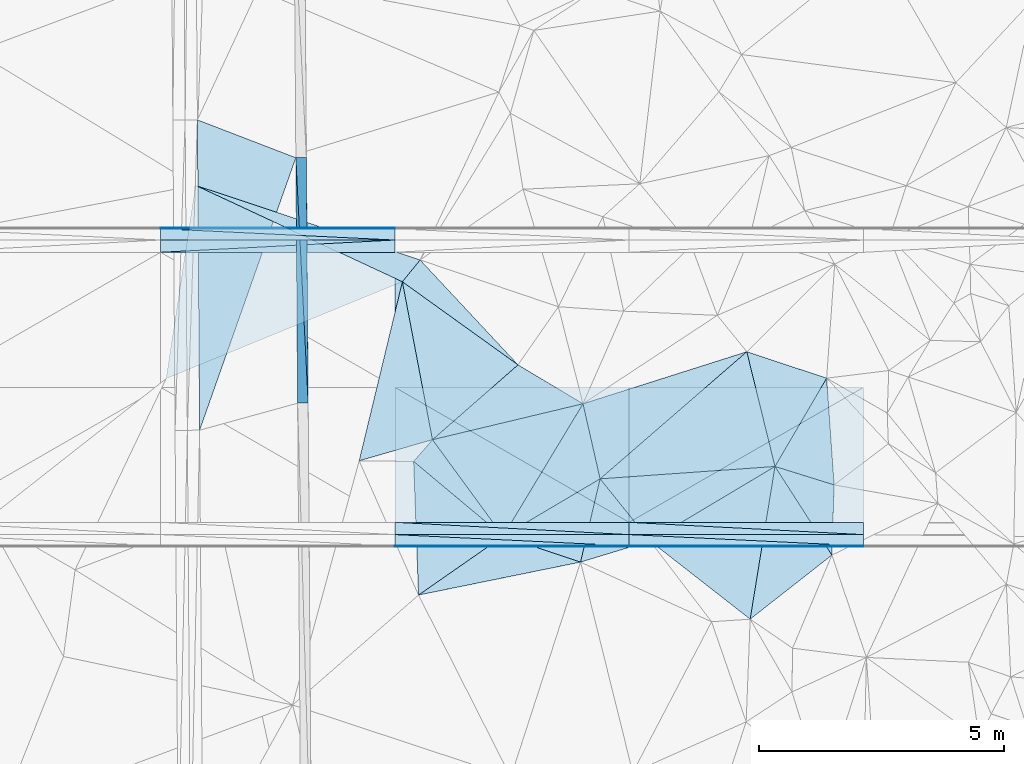
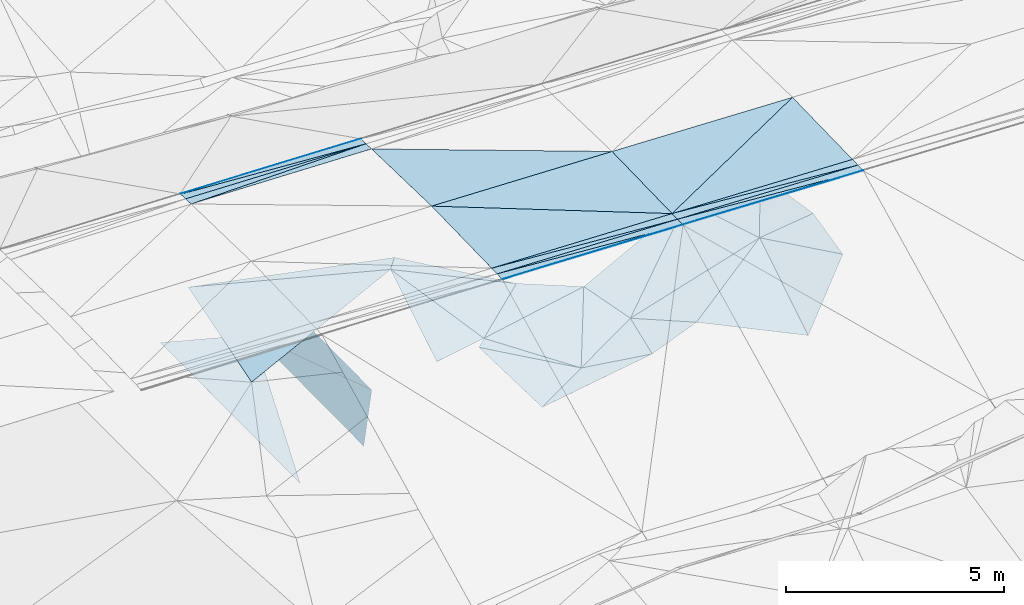
# One storey, part 103 of 275: 47 plates.
"""IFC2X3 building model written with IfcOpenShell, lengths in millimetres."""

from ifc_helpers import new_model, si_unit, frame, origin_with_axes, place, context, subcontext, project, spatial, polyline, outline, extrude, material, type_object, element, save


model = new_model("IFC2X3")

# Units and contexts
model_context = context("Model", 3, precision=1e-05, world=origin_with_axes())
body_context = subcontext(model_context, "Body", "Model", "MODEL_VIEW")
ifc_project = project(units=[si_unit("LENGTHUNIT", "METRE", prefix="MILLI"), si_unit("AREAUNIT", "SQUARE_METRE"), si_unit("VOLUMEUNIT", "CUBIC_METRE"), si_unit("MASSUNIT", "GRAM", prefix="KILO"), si_unit("TIMEUNIT", "SECOND"), si_unit("PLANEANGLEUNIT", "RADIAN"), si_unit("SOLIDANGLEUNIT", "STERADIAN"), si_unit("THERMODYNAMICTEMPERATUREUNIT", "DEGREE_CELSIUS"), si_unit("LUMINOUSINTENSITYUNIT", "LUMEN")], contexts=[model_context])

# Site, building, storey
site_placement = place(None, origin_with_axes())
site = spatial("IfcSite", under=ifc_project, at=site_placement, CompositionType="ELEMENT")
building_placement = place(site_placement, origin_with_axes())
building = spatial("IfcBuilding", under=site, at=building_placement, Name="Undefined", CompositionType="ELEMENT")
storey_placement = place(building_placement, origin_with_axes())
storey = spatial("IfcBuildingStorey", under=building, at=storey_placement, Name="Undefined", CompositionType="ELEMENT", Elevation=0.0)

# Plates
ifc_material = material()
plate_type_1 = type_object("IfcPlateType", PredefinedType="NOTDEFINED")
plate_1_placement = place(storey_placement, frame((-34157.9374475439, 60538.8599444782, 48090.605421218), z_axis=(-0.0325321157077458, 0.0249808254291287, -0.999158455805913), x_axis=(-0.999470311448704, 5.72619769427513e-05, 0.0325437129672813)))
element("IfcPlate", 1, at=plate_1_placement, inside=storey, type_object=plate_type_1, material=ifc_material, Name="00_PR", context=body_context, shape_type="SweptSolid", body=[
    extrude(outline(polyline([(0.0, 0.0), (4774.68701171875, -1.00262695923448e-08), (2.23766922950745, 2750.8583984375), (0.0, 0.0)])), frame((-8.85201319254618e-08, 2.18876761149539e-07, -0.5000001331573), z_axis=(0.0, 0.0, 1.0), x_axis=(1.0, 0.0, 0.0)), (0.0, 0.0, 1.0), 1.0),
])
plate_2_placement = place(storey_placement, frame((-38930.093993772, 60539.1338636758, 48245.9913795708), z_axis=(-0.0298814330532666, 0.0249827413722375, -0.999241193402379), x_axis=(-0.999553127145901, 5.73739658806301e-05, 0.0298921849498749)))
element("IfcPlate", 2, at=plate_2_placement, inside=storey, type_object=plate_type_1, material=ifc_material, Name="00_PR", context=body_context, shape_type="SweptSolid", body=[
    extrude(outline(polyline([(0.0, 0.0), (4774.2900390625, -3.89263732358813e-09), (4776.34521484375, 2750.8583984375), (0.0, 0.0)])), frame((-8.85201319254618e-08, 2.18876761149539e-07, -0.5000001331573), z_axis=(0.0, 0.0, 1.0), x_axis=(1.0, 0.0, 0.0)), (0.0, 0.0, 1.0), 1.0),
])
plate_3_placement = place(storey_placement, frame((-38929.9364341734, 63289.1089021163, 48314.741379141), z_axis=(-0.0298842901449347, -0.024979317513143, -0.999241193555946), x_axis=(-0.999553127145901, 5.73739658806301e-05, 0.0298921849498749)))
element("IfcPlate", 3, at=plate_3_placement, inside=storey, type_object=plate_type_1, material=ifc_material, Name="00_PR", context=body_context, shape_type="SweptSolid", body=[
    extrude(outline(polyline([(0.0, 0.0), (4774.2900390625, -3.89263732358813e-09), (4772.23486328125, 2750.8583984375), (0.0, 0.0)])), frame((-8.85201319254618e-08, 2.18876761149539e-07, -0.5000001331573), z_axis=(0.0, 0.0, 1.0), x_axis=(1.0, 0.0, 0.0)), (0.0, 0.0, 1.0), 1.0),
])
plate_4_placement = place(storey_placement, frame((-38929.9377585435, 63289.1338821415, 48314.7414204442), z_axis=(-0.0325321157077458, 0.0249808254291287, -0.999158455805913), x_axis=(0.999470311737321, -5.73689731605573e-05, -0.0325437039149539)))
element("IfcPlate", 4, at=plate_4_placement, inside=storey, type_object=plate_type_1, material=ifc_material, Name="00_PR", context=body_context, shape_type="SweptSolid", body=[
    extrude(outline(polyline([(0.0, 0.0), (4774.68701171875, -1.00262695923448e-08), (2.23766922950745, 2750.8583984375), (0.0, 0.0)])), frame((-8.85201319254618e-08, 2.18876761149539e-07, -0.5000001331573), z_axis=(0.0, 0.0, 1.0), x_axis=(1.0, 0.0, 0.0)), (0.0, 0.0, 1.0), 1.0),
])
plate_5_placement = place(storey_placement, frame((-43702.0929854815, 63289.4072910054, 48457.4553789251), z_axis=(-0.0298814330532666, 0.0249827413722375, -0.999241193402379), x_axis=(0.999553126962381, -5.74589773414719e-05, -0.0298921909232467)))
element("IfcPlate", 5, at=plate_5_placement, inside=storey, type_object=plate_type_1, material=ifc_material, Name="00_PR", context=body_context, shape_type="SweptSolid", body=[
    extrude(outline(polyline([(0.0, 0.0), (4774.2900390625, -3.89263732358813e-09), (4776.34521484375, 2750.8583984375), (0.0, 0.0)])), frame((-8.85201319254618e-08, 2.18876761149539e-07, -0.5000001331573), z_axis=(0.0, 0.0, 1.0), x_axis=(1.0, 0.0, 0.0)), (0.0, 0.0, 1.0), 1.0),
])
plate_type_2 = type_object("IfcPlateType", PredefinedType="NOTDEFINED")
for number, where, z_axis, x_axis, name in (
    (6, (-45503.7460756443, 67967.3993945954, 44230.9822890553), (0.989899584318774, 0.00994503125413053, -0.141421035630745), (0.00717820600795642, -0.999772985781101, -0.0200611629984491), "00_PR"),
    (7, (-45682.1283943316, 62965.989006159, 42630.6562892526), (0.989899584318774, 0.00994503125413053, -0.141421035630745), (-0.00717820602762173, 0.99977298578046, 0.0200611630233576), "00_PR"),
):
    element("IfcPlate", number, at=place(storey_placement, frame(where, z_axis=z_axis, x_axis=x_axis)), inside=storey, type_object=plate_type_2, material=ifc_material, Name=name, context=body_context, shape_type="SweptSolid", body=[
        extrude(outline(polyline([(0.0, 0.0), (5001.00634765625, -9.82254277914763e-09), (30.0926761627197, 1514.93005371094), (0.0, 0.0)])), frame((-8.85201319254618e-08, 2.18876761149539e-07, -0.5000001331573), z_axis=(0.0, 0.0, 1.0), x_axis=(1.0, 0.0, 0.0)), (0.0, 0.0, 1.0), 1.0),
    ])
plate_type_3 = type_object("IfcPlateType", PredefinedType="NOTDEFINED")
plate_6_placement = place(storey_placement, frame((-43701.9197802606, 66289.3823331968, 48382.4553434521), z_axis=(-0.0272340175232394, -0.0249813615869036, -0.999316886609452), x_axis=(-5.7277968073799e-05, -0.999687644772795, 0.0249921909375039)))
element("IfcPlate", 8, at=plate_6_placement, inside=storey, type_object=plate_type_3, material=ifc_material, Name="00_PR", context=body_context, shape_type="SweptSolid", body=[
    extrude(outline(polyline([(0.0, 0.0), (250.078109741211, 1.02591002359986e-09), (253.32829284668, 4773.92724609375), (0.0, 0.0)])), frame((-8.85201319254618e-08, 2.18876761149539e-07, -0.5000001331573), z_axis=(0.0, 0.0, 1.0), x_axis=(1.0, 0.0, 0.0)), (0.0, 0.0, 1.0), 1.0),
])
plate_7_placement = place(storey_placement, frame((-34157.9517712523, 60288.859943645, 48084.3554209568), z_axis=(-0.0325321157077458, 0.0249808254291287, -0.999158455805913), x_axis=(-0.999470311448704, 5.72619769427513e-05, 0.0325437129672813)))
element("IfcPlate", 9, at=plate_7_placement, inside=storey, type_object=plate_type_3, material=ifc_material, Name="00_PR", context=body_context, shape_type="SweptSolid", body=[
    extrude(outline(polyline([(0.0, 0.0), (4774.68701171875, -1.00262695923448e-08), (4774.890625, 250.078033447266), (0.0, 0.0)])), frame((-8.85201319254618e-08, 2.18876761149539e-07, -0.5000001331573), z_axis=(0.0, 0.0, 1.0), x_axis=(1.0, 0.0, 0.0)), (0.0, 0.0, 1.0), 1.0),
])
plate_8_placement = place(storey_placement, frame((-38930.1083175732, 60289.1338629386, 48239.7413794434), z_axis=(-0.0298814330532666, 0.0249827413722375, -0.999241193402379), x_axis=(-0.999553127145901, 5.73739658806301e-05, 0.0298921849498749)))
element("IfcPlate", 10, at=plate_8_placement, inside=storey, type_object=plate_type_3, material=ifc_material, Name="00_PR", context=body_context, shape_type="SweptSolid", body=[
    extrude(outline(polyline([(0.0, 0.0), (4774.2900390625, -3.89263732358813e-09), (4774.47705078125, 250.078048706055), (0.0, 0.0)])), frame((-8.85201319254618e-08, 2.18876761149539e-07, -0.5000001331573), z_axis=(0.0, 0.0, 1.0), x_axis=(1.0, 0.0, 0.0)), (0.0, 0.0, 1.0), 1.0),
])
plate_9_placement = place(storey_placement, frame((-38930.0953191761, 60539.1338625451, 48245.991420865), z_axis=(-0.0325321157077458, 0.0249808254291287, -0.999158455805913), x_axis=(0.999470311737321, -5.73689731605573e-05, -0.0325437039149539)))
element("IfcPlate", 11, at=plate_9_placement, inside=storey, type_object=plate_type_3, material=ifc_material, Name="00_PR", context=body_context, shape_type="SweptSolid", body=[
    extrude(outline(polyline([(0.0, 0.0), (4774.68701171875, -1.00262695923448e-08), (4774.890625, 250.078033447266), (0.0, 0.0)])), frame((-8.85201319254618e-08, 2.18876761149539e-07, -0.5000001331573), z_axis=(0.0, 0.0, 1.0), x_axis=(1.0, 0.0, 0.0)), (0.0, 0.0, 1.0), 1.0),
])
plate_10_placement = place(storey_placement, frame((-43702.2505460078, 60539.407271133, 48388.7053794016), z_axis=(-0.0298814330532666, 0.0249827413722375, -0.999241193402379), x_axis=(0.999553126962381, -5.74589773414719e-05, -0.0298921909232467)))
element("IfcPlate", 12, at=plate_10_placement, inside=storey, type_object=plate_type_3, material=ifc_material, Name="00_PR", context=body_context, shape_type="SweptSolid", body=[
    extrude(outline(polyline([(0.0, 0.0), (4774.2900390625, -3.89263732358813e-09), (4774.47705078125, 250.078048706055), (0.0, 0.0)])), frame((-8.85201319254618e-08, 2.18876761149539e-07, -0.5000001331573), z_axis=(0.0, 0.0, 1.0), x_axis=(1.0, 0.0, 0.0)), (0.0, 0.0, 1.0), 1.0),
])
plate_11_placement = place(storey_placement, frame((-48474.0906561354, 66039.655737399, 48518.7523406711), z_axis=(-0.0272340175232394, -0.0249813615869036, -0.999316886609452), x_axis=(5.72779774420735e-05, 0.999687644773175, -0.0249921909222736)))
element("IfcPlate", 13, at=plate_11_placement, inside=storey, type_object=plate_type_3, material=ifc_material, Name="00_PR", context=body_context, shape_type="SweptSolid", body=[
    extrude(outline(polyline([(0.0, 0.0), (250.078109741211, 1.02591002359986e-09), (253.32829284668, 4773.92724609375), (0.0, 0.0)])), frame((-8.85201319254618e-08, 2.18876761149539e-07, -0.5000001331573), z_axis=(0.0, 0.0, 1.0), x_axis=(1.0, 0.0, 0.0)), (0.0, 0.0, 1.0), 1.0),
])
plate_type_4 = type_object("IfcPlateType", PredefinedType="NOTDEFINED")
plate_12_placement = place(storey_placement, frame((-47724.1106848693, 68737.1151815157, 42746.347100225), z_axis=(-0.000165521397723103, 0.0200438976469184, -0.999799087201917), x_axis=(0.933340697022024, -0.358916592006958, -0.00735005201020658)))
element("IfcPlate", 14, at=plate_12_placement, inside=storey, type_object=plate_type_4, material=ifc_material, Name="00_PR", context=body_context, shape_type="SweptSolid", body=[
    extrude(outline(polyline([(0.0, 0.0), (2148.82836914063, 1.52795109897852e-10), (2312.06665039063, 5884.70458984375), (0.0, 0.0)])), frame((-8.85201319254618e-08, 2.18876761149539e-07, -0.5000001331573), z_axis=(0.0, 0.0, 1.0), x_axis=(1.0, 0.0, 0.0)), (0.0, 0.0, 1.0), 1.0),
])
plate_type_5 = type_object("IfcPlateType", PredefinedType="NOTDEFINED")
plate_13_placement = place(storey_placement, frame((-43701.90544264, 66539.3698662172, 48369.9558103486), z_axis=(-0.0272099867739145, -0.0499168381754107, -0.998382655040808), x_axis=(-5.44309877651753e-05, -0.998752377894856, 0.0499368069327535)))
element("IfcPlate", 15, at=plate_13_placement, inside=storey, type_object=plate_type_5, material=ifc_material, Name="00_PR", context=body_context, shape_type="SweptSolid", body=[
    extrude(outline(polyline([(0.0, 0.0), (20.0253086090088, -9.45874489843845e-11), (26.5061302185059, 4773.923828125), (0.0, 0.0)])), frame((-8.85201319254618e-08, 2.18876761149539e-07, -0.5000001331573), z_axis=(0.0, 0.0, 1.0), x_axis=(1.0, 0.0, 0.0)), (0.0, 0.0, 1.0), 1.0),
])
plate_14_placement = place(storey_placement, frame((-48474.0630868171, 66519.6429489651, 48501.0028100374), z_axis=(-0.0272099867739145, -0.0499168381754107, -0.998382655040808), x_axis=(5.4430974321816e-05, 0.998752377894704, -0.0499368069357979)))
element("IfcPlate", 16, at=plate_14_placement, inside=storey, type_object=plate_type_5, material=ifc_material, Name="00_PR", context=body_context, shape_type="SweptSolid", body=[
    extrude(outline(polyline([(0.0, 0.0), (20.0253086090088, -9.45874489843845e-11), (26.5060367584229, 4773.923828125), (0.0, 0.0)])), frame((-8.85201319254618e-08, 2.18876761149539e-07, -0.5000001331573), z_axis=(0.0, 0.0, 1.0), x_axis=(1.0, 0.0, 0.0)), (0.0, 0.0, 1.0), 1.0),
])
plate_15_placement = place(storey_placement, frame((-38930.1239487531, 60039.1463257121, 48227.2418879699), z_axis=(-0.0325002803472709, 0.0499121934702922, -0.998224676473354), x_axis=(0.999468574026026, 0.00413144701717349, -0.0323342029424986)))
element("IfcPlate", 17, at=plate_15_placement, inside=storey, type_object=plate_type_5, material=ifc_material, Name="00_PR", context=body_context, shape_type="SweptSolid", body=[
    extrude(outline(polyline([(0.0, 0.0), (4774.6962890625, 1.67856342159212e-08), (4774.64501953125, 20.0252437591553), (0.0, 0.0)])), frame((-8.85201319254618e-08, 2.18876761149539e-07, -0.5000001331573), z_axis=(0.0, 0.0, 1.0), x_axis=(1.0, 0.0, 0.0)), (0.0, 0.0, 1.0), 1.0),
])
plate_16_placement = place(storey_placement, frame((-38930.1239487531, 60039.1463257121, 48227.2418879699), z_axis=(-0.0325002875497137, 0.0499151268677753, -0.998224529561842), x_axis=(7.45909809467971e-05, 0.998752262586527, 0.0499390870409045)))
element("IfcPlate", 18, at=plate_16_placement, inside=storey, type_object=plate_type_5, material=ifc_material, Name="00_PR", context=body_context, shape_type="SweptSolid", body=[
    extrude(outline(polyline([(0.0, 0.0), (20.0243949890137, 1.30967237055302e-10), (12.3478574752808, 4774.68017578125), (0.0, 0.0)])), frame((-8.85201319254618e-08, 2.18876761149539e-07, -0.5000001331573), z_axis=(0.0, 0.0, 1.0), x_axis=(1.0, 0.0, 0.0)), (0.0, 0.0, 1.0), 1.0),
])
plate_17_placement = place(storey_placement, frame((-43702.2791780463, 60039.4197361589, 48369.9558467283), z_axis=(-0.0298520675905743, 0.049919054134539, -0.998307037987252), x_axis=(0.999550833488932, 0.00413170301938356, -0.0296826599505676)))
element("IfcPlate", 19, at=plate_17_placement, inside=storey, type_object=plate_type_5, material=ifc_material, Name="00_PR", context=body_context, shape_type="SweptSolid", body=[
    extrude(outline(polyline([(0.0, 0.0), (4774.302734375, 3.43425199389458e-09), (4774.248046875, 20.024320602417), (0.0, 0.0)])), frame((-8.85201319254618e-08, 2.18876761149539e-07, -0.5000001331573), z_axis=(0.0, 0.0, 1.0), x_axis=(1.0, 0.0, 0.0)), (0.0, 0.0, 1.0), 1.0),
])
plate_18_placement = place(storey_placement, frame((-43702.2780896238, 60059.4200617321, 48370.9558457568), z_axis=(-0.0298520608430818, 0.0499161715220141, -0.998307182326165), x_axis=(0.999553126962381, -5.74589773414719e-05, -0.0298921909232467)))
element("IfcPlate", 20, at=plate_18_placement, inside=storey, type_object=plate_type_5, material=ifc_material, Name="00_PR", context=body_context, shape_type="SweptSolid", body=[
    extrude(outline(polyline([(0.0, 0.0), (4774.29052734375, -1.38679752126336e-08), (0.0299522466957569, 20.0252876281738), (0.0, 0.0)])), frame((-8.85201319254618e-08, 2.18876761149539e-07, -0.5000001331573), z_axis=(0.0, 0.0, 1.0), x_axis=(1.0, 0.0, 0.0)), (0.0, 0.0, 1.0), 1.0),
])
plate_type_6 = type_object("IfcPlateType", PredefinedType="NOTDEFINED")
plate_19_placement = place(storey_placement, frame((-43701.9065353854, 66519.3695414536, 48370.9558105566), z_axis=(-0.0272099867739145, -0.0499168381754107, -0.998382655040808), x_axis=(-5.74669840174811e-05, -0.998752333725473, 0.0499376869254844)))
element("IfcPlate", 21, at=plate_19_placement, inside=storey, type_object=plate_type_6, material=ifc_material, Name="00_PR", context=body_context, shape_type="SweptSolid", body=[
    extrude(outline(polyline([(0.0, 0.0), (230.287002563477, 1.30967237055302e-09), (6.49541330337524, 4773.923828125), (0.0, 0.0)])), frame((-8.85201319254618e-08, 2.18876761149539e-07, -0.5000001331573), z_axis=(0.0, 0.0, 1.0), x_axis=(1.0, 0.0, 0.0)), (0.0, 0.0, 1.0), 1.0),
])
plate_20_placement = place(storey_placement, frame((-34157.9649889068, 60058.8727329078, 48072.8558879903), z_axis=(-0.0325002803472709, 0.0499121934702922, -0.998224676473354), x_axis=(-0.999470311448704, 5.72619769427513e-05, 0.0325437129672813)))
element("IfcPlate", 22, at=plate_20_placement, inside=storey, type_object=plate_type_6, material=ifc_material, Name="00_PR", context=body_context, shape_type="SweptSolid", body=[
    extrude(outline(polyline([(0.0, 0.0), (4774.6865234375, -1.1306838132441e-08), (4775.06103515625, 230.287612915039), (0.0, 0.0)])), frame((-8.85201319254618e-08, 2.18876761149539e-07, -0.5000001331573), z_axis=(0.0, 0.0, 1.0), x_axis=(1.0, 0.0, 0.0)), (0.0, 0.0, 1.0), 1.0),
])
plate_21_placement = place(storey_placement, frame((-38930.1211324567, 60059.1457384215, 48228.2418464111), z_axis=(-0.0298520593377505, 0.0499171449255381, -0.998307133699734), x_axis=(-0.999553127145901, 5.73739658806301e-05, 0.0298921849498749)))
element("IfcPlate", 23, at=plate_21_placement, inside=storey, type_object=plate_type_6, material=ifc_material, Name="00_PR", context=body_context, shape_type="SweptSolid", body=[
    extrude(outline(polyline([(0.0, 0.0), (4774.29052734375, -1.38679752126336e-08), (4774.63427734375, 230.286743164063), (0.0, 0.0)])), frame((-8.85201319254618e-08, 2.18876761149539e-07, -0.5000001331573), z_axis=(0.0, 0.0, 1.0), x_axis=(1.0, 0.0, 0.0)), (0.0, 0.0, 1.0), 1.0),
])
plate_22_placement = place(storey_placement, frame((-38930.109627057, 60289.1463279817, 48239.7418876524), z_axis=(-0.0325002782701552, 0.0499131720050436, -0.998224627612822), x_axis=(0.999470311737321, -5.73689731605573e-05, -0.0325437039149539)))
element("IfcPlate", 24, at=plate_22_placement, inside=storey, type_object=plate_type_6, material=ifc_material, Name="00_PR", context=body_context, shape_type="SweptSolid", body=[
    extrude(outline(polyline([(0.0, 0.0), (4774.68701171875, -1.00262695923448e-08), (4775.06103515625, 230.286697387695), (0.0, 0.0)])), frame((-8.85201319254618e-08, 2.18876761149539e-07, -0.5000001331573), z_axis=(0.0, 0.0, 1.0), x_axis=(1.0, 0.0, 0.0)), (0.0, 0.0, 1.0), 1.0),
])
plate_23_placement = place(storey_placement, frame((-43702.2648547757, 60289.419737419, 48382.4558461127), z_axis=(-0.0298520593377505, 0.0499171449255381, -0.998307133699734), x_axis=(0.999553126962381, -5.74589773414719e-05, -0.0298921909232467)))
element("IfcPlate", 25, at=plate_23_placement, inside=storey, type_object=plate_type_6, material=ifc_material, Name="00_PR", context=body_context, shape_type="SweptSolid", body=[
    extrude(outline(polyline([(0.0, 0.0), (4774.2900390625, -3.89263732358813e-09), (4774.63427734375, 230.287658691406), (0.0, 0.0)])), frame((-8.85201319254618e-08, 2.18876761149539e-07, -0.5000001331573), z_axis=(0.0, 0.0, 1.0), x_axis=(1.0, 0.0, 0.0)), (0.0, 0.0, 1.0), 1.0),
])
plate_24_placement = place(storey_placement, frame((-43701.919767376, 66289.3698617424, 48382.4558082558), z_axis=(-0.0272099867739145, -0.0499168381754107, -0.998382655040808), x_axis=(-0.99962889120436, 5.71859775099965e-05, 0.0272410829319488)))
element("IfcPlate", 26, at=plate_24_placement, inside=storey, type_object=plate_type_6, material=ifc_material, Name="00_PR", context=body_context, shape_type="SweptSolid", body=[
    extrude(outline(polyline([(0.0, 0.0), (4773.92822265625, -9.19681042432785e-09), (4773.61474609375, 230.28678894043), (0.0, 0.0)])), frame((-8.85201319254618e-08, 2.18876761149539e-07, -0.5000001331573), z_axis=(0.0, 0.0, 1.0), x_axis=(1.0, 0.0, 0.0)), (0.0, 0.0, 1.0), 1.0),
])
plate_type_7 = type_object("IfcPlateType", PredefinedType="NOTDEFINED")
plate_25_placement = place(storey_placement, frame((-41193.4769205937, 63747.2421856987, 45139.503580566), z_axis=(-0.111366613227186, -0.0435358758497131, -0.992825314429636), x_axis=(-0.810402544676249, 0.582214744691295, 0.0653735928820686)))
element("IfcPlate", 27, at=plate_25_placement, inside=storey, type_object=plate_type_7, material=ifc_material, Name="00", context=body_context, shape_type="SweptSolid", body=[
    extrude(outline(polyline([(0.0, 0.0), (2906.37231445313, 6.44649844616652e-09), (2868.14599609375, 574.31591796875), (0.0, 0.0)])), frame((-8.85201319254618e-08, 2.18876761149539e-07, -0.5000001331573), z_axis=(0.0, 0.0, 1.0), x_axis=(1.0, 0.0, 0.0)), (0.0, 0.0, 1.0), 1.0),
])
plate_type_8 = type_object("IfcPlateType", PredefinedType="NOTDEFINED")
plate_26_placement = place(storey_placement, frame((-39869.9635809956, 62954.7426554787, 45069.5005601061), z_axis=(-0.0313668012308869, 0.0358435612352073, -0.998865037379185), x_axis=(-0.972409187475183, -0.232222747511436, 0.02220287486103)))
element("IfcPlate", 28, at=plate_26_placement, inside=storey, type_object=plate_type_8, material=ifc_material, Name="00", context=body_context, shape_type="SweptSolid", body=[
    extrude(outline(polyline([(0.0, 0.0), (3152.74487304688, 6.00630301050842e-09), (1104.46618652344, 1079.23791503906), (0.0, 0.0)])), frame((-8.85201319254618e-08, 2.18876761149539e-07, -0.5000001331573), z_axis=(0.0, 0.0, 1.0), x_axis=(1.0, 0.0, 0.0)), (0.0, 0.0, 1.0), 1.0),
])
plate_type_9 = type_object("IfcPlateType", PredefinedType="NOTDEFINED")
plate_27_placement = place(storey_placement, frame((-41497.8959382416, 60256.0232706446, 44999.5187288229), z_axis=(-0.246954156076074, -0.112051443647726, -0.96252694444011), x_axis=(-0.761411867426491, 0.63683448553507, 0.121218010936436)))
element("IfcPlate", 29, at=plate_27_placement, inside=storey, type_object=plate_type_9, material=ifc_material, Name="00", context=body_context, shape_type="SweptSolid", body=[
    extrude(outline(polyline([(0.0, 0.0), (2392.3837890625, -5.58247847948223e-09), (2364.16918945313, 604.238342285156), (0.0, 0.0)])), frame((-8.85201319254618e-08, 2.18876761149539e-07, -0.5000001331573), z_axis=(0.0, 0.0, 1.0), x_axis=(1.0, 0.0, 0.0)), (0.0, 0.0, 1.0), 1.0),
])
plate_type_10 = type_object("IfcPlateType", PredefinedType="NOTDEFINED")
plate_28_placement = place(storey_placement, frame((-35959.1108458606, 61676.9130750273, 45839.5441145695), z_axis=(0.388513059727075, 0.133253487645779, -0.911757155415708), x_axis=(0.537128762741228, -0.836738607024765, 0.106588910071983)))
element("IfcPlate", 30, at=plate_28_placement, inside=storey, type_object=plate_type_10, material=ifc_material, Name="00", context=body_context, shape_type="SweptSolid", body=[
    extrude(outline(polyline([(0.0, 0.0), (2157.82299804688, 4.2600731831044e-09), (2259.26782226563, 2296.21630859375), (0.0, 0.0)])), frame((-8.85201319254618e-08, 2.18876761149539e-07, -0.5000001331573), z_axis=(0.0, 0.0, 1.0), x_axis=(1.0, 0.0, 0.0)), (0.0, 0.0, 1.0), 1.0),
])
plate_type_11 = type_object("IfcPlateType", PredefinedType="NOTDEFINED")
plate_29_placement = place(storey_placement, frame((-47762.6266655501, 67403.2339926933, 45119.5007094845), z_axis=(0.0530921271819162, 0.00714240041058882, -0.998564075133726), x_axis=(0.905478430460294, -0.421986474535989, 0.0451245751209873)))
element("IfcPlate", 31, at=plate_29_placement, inside=storey, type_object=plate_type_11, material=ifc_material, Name="00", context=body_context, shape_type="SweptSolid", body=[
    extrude(outline(polyline([(0.0, 0.0), (4653.783203125, -7.75617081671953e-09), (1117.15551757813, 3824.23364257813), (0.0, 0.0)])), frame((-8.85201319254618e-08, 2.18876761149539e-07, -0.5000001331573), z_axis=(0.0, 0.0, 1.0), x_axis=(1.0, 0.0, 0.0)), (0.0, 0.0, 1.0), 1.0),
])
plate_type_12 = type_object("IfcPlateType", PredefinedType="NOTDEFINED")
plate_30_placement = place(storey_placement, frame((-34800.0701555888, 59871.3877640824, 46069.5507080592), z_axis=(0.412318095275695, 0.150214451215539, -0.8985707579007), x_axis=(-0.537128762739844, 0.836738607025903, -0.106588910070026)))
element("IfcPlate", 32, at=plate_30_placement, inside=storey, type_object=plate_type_12, material=ifc_material, Name="00", context=body_context, shape_type="SweptSolid", body=[
    extrude(outline(polyline([(0.0, 0.0), (2157.82299804688, 4.2600731831044e-09), (1144.85754394531, 897.44140625), (0.0, 0.0)])), frame((-8.85201319254618e-08, 2.18876761149539e-07, -0.5000001331573), z_axis=(0.0, 0.0, 1.0), x_axis=(1.0, 0.0, 0.0)), (0.0, 0.0, 1.0), 1.0),
])
plate_type_13 = type_object("IfcPlateType", PredefinedType="NOTDEFINED")
plate_31_placement = place(storey_placement, frame((-39521.5762694965, 61424.862168162, 44989.5083966454), z_axis=(0.129278043707092, -0.128921874177972, -0.983191912992426), x_axis=(0.616552508410687, -0.766101600570493, 0.181525045037368)))
element("IfcPlate", 33, at=plate_31_placement, inside=storey, type_object=plate_type_13, material=ifc_material, Name="00", context=body_context, shape_type="SweptSolid", body=[
    extrude(outline(polyline([(0.0, 0.0), (1652.66455078125, -4.40923031419516e-09), (1084.49108886719, 1373.81909179688), (0.0, 0.0)])), frame((-8.85201319254618e-08, 2.18876761149539e-07, -0.5000001331573), z_axis=(0.0, 0.0, 1.0), x_axis=(1.0, 0.0, 0.0)), (0.0, 0.0, 1.0), 1.0),
])
plate_type_14 = type_object("IfcPlateType", PredefinedType="NOTDEFINED")
plate_32_placement = place(storey_placement, frame((-43548.8017699451, 65439.416783953, 45329.5028067756), z_axis=(-0.0981035545848413, 0.0400360281974493, -0.994370559210193), x_axis=(0.186892344578921, -0.980671285671378, -0.0579230610158082)))
element("IfcPlate", 34, at=plate_32_placement, inside=storey, type_object=plate_type_14, material=ifc_material, Name="00", context=body_context, shape_type="SweptSolid", body=[
    extrude(outline(polyline([(0.0, 0.0), (3280.21337890625, -5.04223862662911e-09), (3415.87524414063, 1553.76831054688), (0.0, 0.0)])), frame((-8.85201319254618e-08, 2.18876761149539e-07, -0.5000001331573), z_axis=(0.0, 0.0, 1.0), x_axis=(1.0, 0.0, 0.0)), (0.0, 0.0, 1.0), 1.0),
])
plate_type_15 = type_object("IfcPlateType", PredefinedType="NOTDEFINED")
plate_33_placement = place(storey_placement, frame((-39919.9285378937, 59728.9507435729, 45159.5126602421), z_axis=(0.0245799010244903, -0.222314260995747, -0.974665172160954), x_axis=(-0.97969320663077, -0.199422676560041, 0.0207802058495477)))
element("IfcPlate", 35, at=plate_33_placement, inside=storey, type_object=plate_type_15, material=ifc_material, Name="00", context=body_context, shape_type="SweptSolid", body=[
    extrude(outline(polyline([(0.0, 0.0), (3368.59008789063, -1.05355866253376e-08), (1437.36682128906, 852.570495605469), (0.0, 0.0)])), frame((-8.85201319254618e-08, 2.18876761149539e-07, -0.5000001331573), z_axis=(0.0, 0.0, 1.0), x_axis=(1.0, 0.0, 0.0)), (0.0, 0.0, 1.0), 1.0),
])
plate_type_16 = type_object("IfcPlateType", PredefinedType="NOTDEFINED")
plate_34_placement = place(storey_placement, frame((-43187.4371271881, 65883.3466863807, 45269.504021913), z_axis=(-0.0094509444761308, -0.126351259851117, -0.991940541959318), x_axis=(-0.627742689449551, -0.771409639295286, 0.104241470849954)))
element("IfcPlate", 36, at=plate_34_placement, inside=storey, type_object=plate_type_16, material=ifc_material, Name="00", context=body_context, shape_type="SweptSolid", body=[
    extrude(outline(polyline([(0.0, 0.0), (575.586669921875, 2.3283064365387e-09), (1684.02099609375, 4519.85302734375), (0.0, 0.0)])), frame((-8.85201319254618e-08, 2.18876761149539e-07, -0.5000001331573), z_axis=(0.0, 0.0, 1.0), x_axis=(1.0, 0.0, 0.0)), (0.0, 0.0, 1.0), 1.0),
])
plate_type_17 = type_object("IfcPlateType", PredefinedType="NOTDEFINED")
plate_35_placement = place(storey_placement, frame((-39869.963734713, 62954.7472352016, 45069.5007503913), z_axis=(-0.0316718805464196, 0.045004129264679, -0.998484611965443), x_axis=(0.221712210599353, -0.973781547780758, -0.0509234020157634)))
element("IfcPlate", 37, at=plate_35_placement, inside=storey, type_object=plate_type_17, material=ifc_material, Name="00", context=body_context, shape_type="SweptSolid", body=[
    extrude(outline(polyline([(0.0, 0.0), (1570.98693847656, 2.43744580075145e-10), (2270.54711914063, 2186.78198242188), (0.0, 0.0)])), frame((-8.85201319254618e-08, 2.18876761149539e-07, -0.5000001331573), z_axis=(0.0, 0.0, 1.0), x_axis=(1.0, 0.0, 0.0)), (0.0, 0.0, 1.0), 1.0),
])
plate_type_18 = type_object("IfcPlateType", PredefinedType="NOTDEFINED")
plate_36_placement = place(storey_placement, frame((-36533.3154936799, 64014.2875102363, 45649.5226910322), z_axis=(0.297846586074072, -0.00443358964498966, -0.954603454030458), x_axis=(0.909906986885083, -0.301120511369249, 0.285299339029082)))
element("IfcPlate", 38, at=plate_36_placement, inside=storey, type_object=plate_type_18, material=ifc_material, Name="00", context=body_context, shape_type="SweptSolid", body=[
    extrude(outline(polyline([(0.0, 0.0), (1787.59619140625, 3.41242412105203e-09), (1280.49060058594, 2046.88635253906), (0.0, 0.0)])), frame((-8.85201319254618e-08, 2.18876761149539e-07, -0.5000001331573), z_axis=(0.0, 0.0, 1.0), x_axis=(1.0, 0.0, 0.0)), (0.0, 0.0, 1.0), 1.0),
])
plate_type_19 = type_object("IfcPlateType", PredefinedType="NOTDEFINED")
plate_37_placement = place(storey_placement, frame((-41497.7893897406, 60256.1024559458, 44999.5008160029), z_axis=(-0.033856661409763, 0.0463185715746608, -0.998352801571402), x_axis=(-0.589277410510836, 0.805891090632798, 0.0573731949635315)))
element("IfcPlate", 39, at=plate_37_placement, inside=storey, type_object=plate_type_19, material=ifc_material, Name="00", context=body_context, shape_type="SweptSolid", body=[
    extrude(outline(polyline([(0.0, 0.0), (2440.16381835938, 6.74481270834804e-09), (1219.59020996094, 2906.88842773438), (0.0, 0.0)])), frame((-8.85201319254618e-08, 2.18876761149539e-07, -0.5000001331573), z_axis=(0.0, 0.0, 1.0), x_axis=(1.0, 0.0, 0.0)), (0.0, 0.0, 1.0), 1.0),
])
plate_type_20 = type_object("IfcPlateType", PredefinedType="NOTDEFINED")
plate_38_placement = place(storey_placement, frame((-38502.5691279452, 60158.7970621863, 45289.5143913954), z_axis=(0.234654920218013, -0.0412744502377935, -0.971202084107652), x_axis=(-0.616552508408195, 0.766101600571861, -0.181525045040057)))
element("IfcPlate", 40, at=plate_38_placement, inside=storey, type_object=plate_type_20, material=ifc_material, Name="00", context=body_context, shape_type="SweptSolid", body=[
    extrude(outline(polyline([(0.0, 0.0), (1652.66455078125, -4.40923031419516e-09), (-505.002685546875, 2969.96166992188), (0.0, 0.0)])), frame((-8.85201319254618e-08, 2.18876761149539e-07, -0.5000001331573), z_axis=(0.0, 0.0, 1.0), x_axis=(1.0, 0.0, 0.0)), (0.0, 0.0, 1.0), 1.0),
])
plate_type_21 = type_object("IfcPlateType", PredefinedType="NOTDEFINED")
plate_39_placement = place(storey_placement, frame((-36533.3476734849, 64014.2788936732, 45649.5139336987), z_axis=(0.233486948798498, -0.0216663271556909, -0.972118519013165), x_axis=(0.237804729560832, -0.968119911762839, 0.0786940089639081)))
element("IfcPlate", 41, at=plate_39_placement, inside=storey, type_object=plate_type_21, material=ifc_material, Name="00", context=body_context, shape_type="SweptSolid", body=[
    extrude(outline(polyline([(0.0, 0.0), (2414.4150390625, 2.99769453704357e-09), (1744.2734375, 3609.30883789063), (0.0, 0.0)])), frame((-8.85201319254618e-08, 2.18876761149539e-07, -0.5000001331573), z_axis=(0.0, 0.0, 1.0), x_axis=(1.0, 0.0, 0.0)), (0.0, 0.0, 1.0), 1.0),
])
plate_type_22 = type_object("IfcPlateType", PredefinedType="NOTDEFINED")
plate_40_placement = place(storey_placement, frame((-43548.7748164684, 65439.4220211406, 45329.501119403), z_axis=(-0.0441997860365982, 0.0505081055608357, -0.997745112835425), x_axis=(0.810402544659122, -0.582214744708866, -0.0653735929378962)))
element("IfcPlate", 42, at=plate_40_placement, inside=storey, type_object=plate_type_22, material=ifc_material, Name="00", context=body_context, shape_type="SweptSolid", body=[
    extrude(outline(polyline([(0.0, 0.0), (2906.37231445313, 6.44649844616652e-09), (2382.11059570313, 2255.07202148438), (0.0, 0.0)])), frame((-8.85201319254618e-08, 2.18876761149539e-07, -0.5000001331573), z_axis=(0.0, 0.0, 1.0), x_axis=(1.0, 0.0, 0.0)), (0.0, 0.0, 1.0), 1.0),
])
plate_type_23 = type_object("IfcPlateType", PredefinedType="NOTDEFINED")
plate_41_placement = place(storey_placement, frame((-34754.6412492957, 61301.8252738868, 46329.534842807), z_axis=(0.363734540644128, -0.0472959759642056, -0.930301174136633), x_axis=(-0.890014019467331, 0.277092608571097, -0.362070064251204)))
element("IfcPlate", 43, at=plate_41_placement, inside=storey, type_object=plate_type_23, material=ifc_material, Name="00", context=body_context, shape_type="SweptSolid", body=[
    extrude(outline(polyline([(0.0, 0.0), (1353.32922363281, -6.76664058119059e-10), (799.362060546875, 2034.70397949219), (0.0, 0.0)])), frame((-8.85201319254618e-08, 2.18876761149539e-07, -0.5000001331573), z_axis=(0.0, 0.0, 1.0), x_axis=(1.0, 0.0, 0.0)), (0.0, 0.0, 1.0), 1.0),
])
plate_type_24 = type_object("IfcPlateType", PredefinedType="NOTDEFINED")
plate_42_placement = place(storey_placement, frame((-39521.568629784, 61424.9688638753, 44989.5070502251), z_axis=(0.144557067578393, 0.0844693128834733, -0.985884470612115), x_axis=(-0.221712210594479, 0.973781547782301, 0.0509234020074829)))
element("IfcPlate", 44, at=plate_42_placement, inside=storey, type_object=plate_type_24, material=ifc_material, Name="00", context=body_context, shape_type="SweptSolid", body=[
    extrude(outline(polyline([(0.0, 0.0), (1570.98693847656, 2.43744580075145e-10), (1892.56823730469, 3533.80615234375), (0.0, 0.0)])), frame((-8.85201319254618e-08, 2.18876761149539e-07, -0.5000001331573), z_axis=(0.0, 0.0, 1.0), x_axis=(1.0, 0.0, 0.0)), (0.0, 0.0, 1.0), 1.0),
])
plate_type_25 = type_object("IfcPlateType", PredefinedType="NOTDEFINED")
plate_43_placement = place(storey_placement, frame((-36464.9149310381, 58566.9100135276, 45169.5118764437), z_axis=(0.094780209535066, 0.194901279492806, -0.976232658300549), x_axis=(-0.787171023900461, 0.614990170913661, 0.0463558929488524)))
element("IfcPlate", 45, at=plate_43_placement, inside=storey, type_object=plate_type_25, material=ifc_material, Name="00", context=body_context, shape_type="SweptSolid", body=[
    extrude(outline(polyline([(0.0, 0.0), (2588.66772460938, 2.87400325760245e-09), (1545.66003417969, 2826.27587890625), (0.0, 0.0)])), frame((-8.85201319254618e-08, 2.18876761149539e-07, -0.5000001331573), z_axis=(0.0, 0.0, 1.0), x_axis=(1.0, 0.0, 0.0)), (0.0, 0.0, 1.0), 1.0),
])
plate_type_26 = type_object("IfcPlateType", PredefinedType="NOTDEFINED")
plate_44_placement = place(storey_placement, frame((-43319.4337178633, 61779.6400574369, 45289.5052520654), z_axis=(-0.143668145468846, 0.0165710809035103, -0.989487171849758), x_axis=(0.761411867396404, -0.63683448559202, -0.121218010826233)))
element("IfcPlate", 46, at=plate_44_placement, inside=storey, type_object=plate_type_26, material=ifc_material, Name="00", context=body_context, shape_type="SweptSolid", body=[
    extrude(outline(polyline([(0.0, 0.0), (2392.3837890625, -5.58247847948223e-09), (1816.5146484375, 2030.97875976563), (0.0, 0.0)])), frame((-8.85201319254618e-08, 2.18876761149539e-07, -0.5000001331573), z_axis=(0.0, 0.0, 1.0), x_axis=(1.0, 0.0, 0.0)), (0.0, 0.0, 1.0), 1.0),
])
plate_type_27 = type_object("IfcPlateType", PredefinedType="NOTDEFINED")
plate_45_placement = place(storey_placement, frame((-39919.9096403577, 59729.0048712023, 45159.504238506), z_axis=(0.0624466413677591, -0.114059268459837, -0.991509405028663), x_axis=(-0.944132539646825, 0.315353211218549, -0.0957397501259818)))
element("IfcPlate", 47, at=plate_45_placement, inside=storey, type_object=plate_type_27, material=ifc_material, Name="00", context=body_context, shape_type="SweptSolid", body=[
    extrude(outline(polyline([(0.0, 0.0), (1671.19714355469, 1.33150024339557e-09), (175.024230957031, 1741.5126953125), (0.0, 0.0)])), frame((-8.85201319254618e-08, 2.18876761149539e-07, -0.5000001331573), z_axis=(0.0, 0.0, 1.0), x_axis=(1.0, 0.0, 0.0)), (0.0, 0.0, 1.0), 1.0),
])

save(model, "model.ifc")
